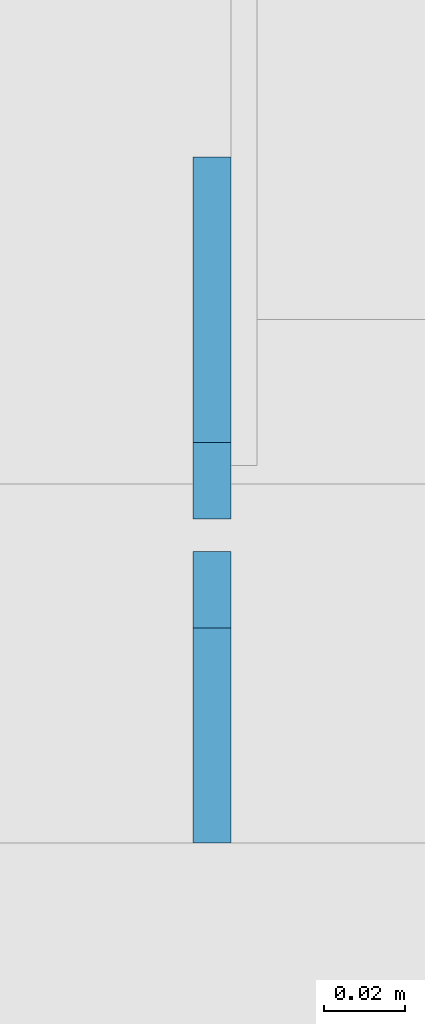
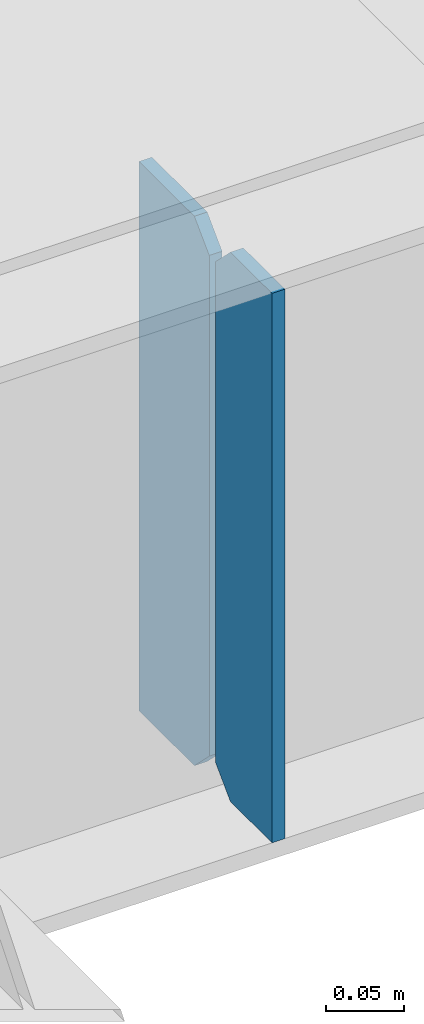
# One storey, part 1600 of 1763: 2 plates, 1 element without a shape of its own.
"""IFC2X3 building model written with IfcOpenShell, lengths in millimetres."""

from ifc_helpers import new_model, si_unit, frame, origin_with_axes, place, context, subcontext, project, spatial, faceted_brep, material, type_object, element, aggregate, save


model = new_model("IFC2X3")

# Units and contexts
model_context = context("Model", 3, precision=1e-05, world=origin_with_axes())
body_context = subcontext(model_context, "Body", "Model", "MODEL_VIEW")
ifc_project = project(units=[si_unit("LENGTHUNIT", "METRE", prefix="MILLI"), si_unit("AREAUNIT", "SQUARE_METRE"), si_unit("VOLUMEUNIT", "CUBIC_METRE"), si_unit("MASSUNIT", "GRAM", prefix="KILO"), si_unit("TIMEUNIT", "SECOND"), si_unit("PLANEANGLEUNIT", "RADIAN"), si_unit("SOLIDANGLEUNIT", "STERADIAN"), si_unit("THERMODYNAMICTEMPERATUREUNIT", "DEGREE_CELSIUS"), si_unit("LUMINOUSINTENSITYUNIT", "LUMEN")], contexts=[model_context])

# Site, building, storey
site_placement = place(None, origin_with_axes())
site = spatial("IfcSite", under=ifc_project, at=site_placement, CompositionType="ELEMENT")
building_placement = place(site_placement, origin_with_axes())
building = spatial("IfcBuilding", under=site, at=building_placement, Name="Undefined", CompositionType="ELEMENT")
storey_placement = place(building_placement, origin_with_axes())
storey = spatial("IfcBuildingStorey", under=building, at=storey_placement, Name="Undefined", CompositionType="ELEMENT", Elevation=0.0)

# Assembly, plates
assembly_placement = place(storey_placement, origin_with_axes())
assembly = element("IfcElementAssembly", 1, at=assembly_placement, inside=storey, Name="BEAM", AssemblyPlace="NOTDEFINED", PredefinedType="RIGID_FRAME")
ifc_material = material(Name="STEEL/A36")
plate_type_1 = type_object("IfcPlateType", PredefinedType="NOTDEFINED")
plate_1_placement = place(assembly_placement, frame((-82079.9341486984, 53568.6, 4752.975), z_axis=(0.0, 0.0, 1.0), x_axis=(0.0, 1.0, 0.0)))
plate_1 = element("IfcPlate", 2, at=plate_1_placement, type_object=plate_type_1, material=ifc_material, Name="PLATE", context=body_context, shape_type="Brep", body=[
    faceted_brep([(0.0, -4.76249999999982, 0.0), (0.0, -4.76249999999709, 428.625), (0.0, 4.76249999999709, 428.625), (0.0, 4.76249999999982, 0.0), (53.1812477111816, -4.76249999999709, 428.625), (53.1812477111816, 4.76249999999709, 428.625), (72.2312469482422, -4.76249999999709, 409.575000762939), (72.2312469482422, 4.76249999999709, 409.575000762939), (72.2312469482422, -4.76249999999709, 19.0499992370605), (72.2312469482422, 4.76249999999709, 19.0499992370605), (53.1812477111816, -4.76249999999709, 0.0), (53.1812477111816, 4.76249999999709, 0.0)], [[[0, 1, 2, 3]], [[1, 4, 5, 2]], [[4, 6, 7, 5]], [[6, 8, 9, 7]], [[8, 10, 11, 9]], [[10, 0, 3, 11]], [[5, 7, 9, 11, 3, 2]], [[10, 8, 6, 4, 1, 0]]]),
])
plate_type_2 = type_object("IfcPlateType", PredefinedType="NOTDEFINED")
plate_2_placement = place(assembly_placement, frame((-82079.9341486984, 53648.76875, 4752.975), z_axis=(0.0, 0.0, 1.0), x_axis=(0.0, 1.0, 0.0)))
plate_2 = element("IfcPlate", 3, at=plate_2_placement, type_object=plate_type_2, material=ifc_material, Name="PLATE", context=body_context, shape_type="Brep", body=[
    faceted_brep([(6.96272763889283e-08, -4.76249999999709, 19.0499992370605), (0.0, -4.76249999999709, 409.575000762939), (0.0, 4.76249999999709, 409.575000762939), (6.96454662829638e-08, 4.76249999999709, 19.0499992370605), (19.0499992370605, -4.76249999999709, 428.625), (19.0499992370605, 4.76249999999709, 428.625), (89.6937484741211, -4.76249999999709, 428.625), (89.6937484741211, 4.76249999999709, 428.625), (89.6937484741211, -4.76249999999709, 0.0), (89.6937484741211, 4.76249999999709, 0.0), (19.0499992370533, -4.76249999996799, -2.09183781407773e-11), (19.0499992370678, 4.76250000003347, -2.09183781407773e-11)], [[[0, 1, 2, 3]], [[1, 4, 5, 2]], [[4, 6, 7, 5]], [[6, 8, 9, 7]], [[8, 10, 11, 9]], [[10, 0, 3, 11]], [[5, 7, 9, 11, 3, 2]], [[10, 8, 6, 4, 1, 0]]]),
])
aggregate(assembly, [plate_1, plate_2])

save(model, "model.ifc")
